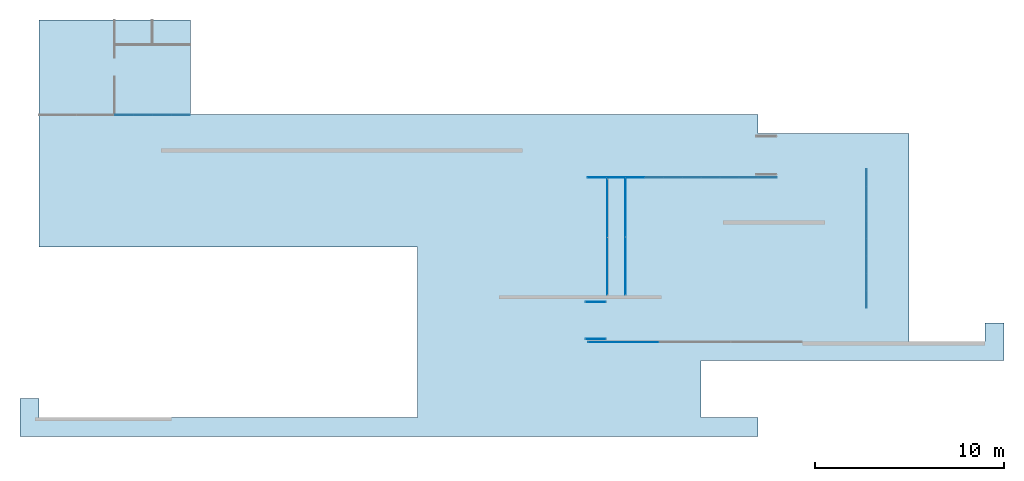
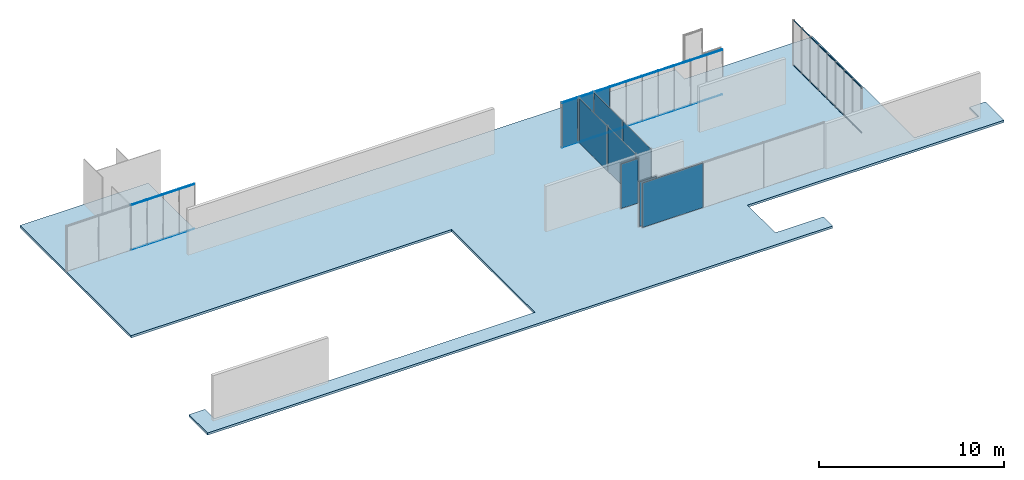
# One storey, part 7 of 8: 44 members, 10 plates, 1 slab, 8 elements without a shape of their own.
"""IFC2X3 building model written with IfcOpenShell, lengths in millimetres."""

from ifc_helpers import new_model, entity, si_unit, converted_unit, direction, frame, frame_2d, origin, origin_2d_with_axis, place, context, subcontext, project, spatial, polyline, rectangle, outline, extrude, source, transform, mapped, material, layer, layer_set, layer_usage, type_object, type_shapes, element, aggregate, save


model = new_model("IFC2X3")

# Units and contexts
model_context = context("Model", 3, precision=1e-06, world=origin(), true_north=direction((2.0, 6.12303176911189e-17, 1.0)))
context_of_model = context(None, 3, precision=1e-06, world=origin(), true_north=direction((2.0, 6.12303176911189e-17, 1.0)))
body_context = subcontext(model_context, "Body", "Model", "MODEL_VIEW")
ifc_project = project(units=[si_unit("LENGTHUNIT", "METRE", prefix="MILLI"), si_unit("AREAUNIT", "SQUARE_METRE", prefix="MILLI"), si_unit("VOLUMEUNIT", "CUBIC_METRE", prefix="MILLI"), converted_unit("PLANEANGLEUNIT", "DEGREE", entity("IfcRatioMeasure", 0.0174532925199433), si_unit("PLANEANGLEUNIT", "RADIAN"), dimensions=[0, 0, 0, 0, 0, 0, 0]), si_unit("TIMEUNIT", "SECOND")], contexts=[model_context, context_of_model])

# Site, building, storey
site_placement = place(None, origin())
site = spatial("IfcSite", under=ifc_project, at=site_placement, CompositionType="ELEMENT")
building_placement = place(site_placement, origin())
building = spatial("IfcBuilding", under=site, at=building_placement, CompositionType="ELEMENT")
storey_placement = place(building_placement, frame((0.0, 0.0, 1500.0)))
storey = spatial("IfcBuildingStorey", under=building, at=storey_placement, Name="Level 1", CompositionType="ELEMENT", Elevation=1500.0)

# Curtain wall, members
curtain_wall_1_placement = place(storey_placement, origin())
curtain_wall_1 = element("IfcCurtainWall", 1, at=curtain_wall_1_placement, inside=storey, Name="Curtain Wall:Curtain Wall", ObjectType="Curtain Wall:Curtain Wall:334")
member_1_placement = place(storey_placement, origin())
member_1 = element("IfcMember", 2, at=member_1_placement, Name="Curtain Wall:Curtain Wall:8490", ObjectType="Curtain Wall:Curtain Wall:8490", context=body_context, shape_type="SweptSolid", body=[
    extrude(rectangle(XDim=971.875, YDim=29.9999999999997, at=frame_2d((1.10844666778576e-12, -5.41788836017076e-13), x_axis=(1.0, 0.0))), frame((-19489.6875, 5875.0, 2970.0), z_axis=(0.0, 0.0, 1.0), x_axis=(-1.0, 0.0, 0.0)), (0.0, 0.0, 1.0), 30.0000000000002),
])
member_2_placement = place(storey_placement, origin())
member_2 = element("IfcMember", 3, at=member_2_placement, Name="Curtain Wall:Curtain Wall:8490", ObjectType="Curtain Wall:Curtain Wall:8490", context=body_context, shape_type="SweptSolid", body=[
    extrude(rectangle(XDim=971.874999999998, YDim=29.9999999999997, at=frame_2d((-2.18847162614111e-12, -5.41788836017076e-13), x_axis=(1.0, 0.0))), frame((-20491.5625, 5875.0, 2970.0), z_axis=(0.0, 0.0, 1.0), x_axis=(-1.0, 0.0, 0.0)), (0.0, 0.0, 1.0), 30.0000000000002),
])
member_3_placement = place(storey_placement, origin())
member_3 = element("IfcMember", 4, at=member_3_placement, Name="Curtain Wall:Curtain Wall:8490", ObjectType="Curtain Wall:Curtain Wall:8490", context=body_context, shape_type="SweptSolid", body=[
    extrude(rectangle(XDim=941.874999999996, YDim=29.9999999999997, at=frame_2d((0.0, -5.41788836017076e-13), x_axis=(1.0, 0.0))), frame((-17500.9375, 5875.0, 0.0)), (0.0, 0.0, 1.0), 29.9999999999999),
])
member_4_placement = place(storey_placement, origin())
member_4 = element("IfcMember", 5, at=member_4_placement, Name="Curtain Wall:Curtain Wall:8490", ObjectType="Curtain Wall:Curtain Wall:8490", context=body_context, shape_type="SweptSolid", body=[
    extrude(rectangle(XDim=971.875, YDim=29.9999999999997, at=frame_2d((-1.10844666778576e-12, -5.41788836017076e-13), x_axis=(1.0, 0.0))), frame((-18487.8125, 5875.0, 0.0)), (0.0, 0.0, 1.0), 29.9999999999999),
])
member_5_placement = place(storey_placement, origin())
member_5 = element("IfcMember", 6, at=member_5_placement, Name="Curtain Wall:Curtain Wall:8490", ObjectType="Curtain Wall:Curtain Wall:8490", context=body_context, shape_type="SweptSolid", body=[
    extrude(rectangle(XDim=971.875, YDim=29.9999999999997, at=frame_2d((-1.10844666778576e-12, 5.41788836017076e-13), x_axis=(1.0, 0.0))), frame((-19489.6875, 5875.0, 0.0)), (0.0, 0.0, 1.0), 29.9999999999999),
])
member_6_placement = place(storey_placement, origin())
member_6 = element("IfcMember", 7, at=member_6_placement, Name="Curtain Wall:Curtain Wall:8490", ObjectType="Curtain Wall:Curtain Wall:8490", context=body_context, shape_type="SweptSolid", body=[
    extrude(rectangle(XDim=971.874999999998, YDim=29.9999999999997, at=frame_2d((2.18847162614111e-12, -5.41788836017076e-13), x_axis=(1.0, 0.0))), frame((-20491.5625, 5875.0, 0.0)), (0.0, 0.0, 1.0), 29.9999999999999),
])
member_7_placement = place(storey_placement, origin())
member_7 = element("IfcMember", 8, at=member_7_placement, Name="Curtain Wall:Curtain Wall:8490", ObjectType="Curtain Wall:Curtain Wall:8490", context=body_context, shape_type="SweptSolid", body=[
    extrude(rectangle(XDim=941.874999999996, YDim=29.9999999999997, at=frame_2d((-2.1600499167107e-12, -5.41788836017076e-13), x_axis=(1.0, 0.0))), frame((-17500.9375, 5875.0, 2970.0), z_axis=(0.0, 0.0, 1.0), x_axis=(-1.0, 0.0, 0.0)), (0.0, 0.0, 1.0), 30.0000000000002),
])
member_8_placement = place(storey_placement, origin())
member_8 = element("IfcMember", 9, at=member_8_placement, Name="Curtain Wall:Curtain Wall:8490", ObjectType="Curtain Wall:Curtain Wall:8490", context=body_context, shape_type="SweptSolid", body=[
    extrude(rectangle(XDim=971.875, YDim=29.9999999999997, at=frame_2d((-1.10844666778576e-12, 5.41788836017076e-13), x_axis=(1.0, 0.0))), frame((-18487.8125, 5875.0, 2970.0), z_axis=(0.0, 0.0, 1.0), x_axis=(-1.0, 0.0, 0.0)), (0.0, 0.0, 1.0), 30.0000000000002),
])
aggregate(curtain_wall_1, [member_1, member_2, member_3, member_4, member_5, member_6, member_7, member_8])

curtain_wall_2_placement = place(storey_placement, origin())
curtain_wall_2 = element("IfcCurtainWall", 10, at=curtain_wall_2_placement, inside=storey, Name="Curtain Wall:Curtain Wall", ObjectType="Curtain Wall:Curtain Wall:334")
member_9_placement = place(storey_placement, origin())
member_9 = element("IfcMember", 11, at=member_9_placement, Name="Curtain Wall:Curtain Wall:8490", ObjectType="Curtain Wall:Curtain Wall:8490", context=body_context, shape_type="SweptSolid", body=[
    extrude(rectangle(XDim=971.5, YDim=30.0000000000002, at=frame_2d((0.0, 2.70894418008538e-13), x_axis=(1.0, 0.0))), frame((5494.75, 2575.0, 2970.0)), (0.0, 0.0, 1.0), 30.0000000000002),
])
member_10_placement = place(storey_placement, origin())
member_10 = element("IfcMember", 12, at=member_10_placement, Name="Curtain Wall:Curtain Wall:8490", ObjectType="Curtain Wall:Curtain Wall:8490", context=body_context, shape_type="SweptSolid", body=[
    extrude(rectangle(XDim=971.5, YDim=30.0000000000002, at=frame_2d((0.0, 2.70894418008538e-13), x_axis=(1.0, 0.0))), frame((6496.25, 2575.0, 2970.0)), (0.0, 0.0, 1.0), 30.0000000000002),
])
member_11_placement = place(storey_placement, origin())
member_11 = element("IfcMember", 13, at=member_11_placement, Name="Curtain Wall:Curtain Wall:8490", ObjectType="Curtain Wall:Curtain Wall:8490", context=body_context, shape_type="SweptSolid", body=[
    extrude(rectangle(XDim=971.5, YDim=30.0000000000002, at=frame_2d((0.0, 2.70894418008538e-13), x_axis=(1.0, 0.0))), frame((7497.75, 2575.0, 2970.0)), (0.0, 0.0, 1.0), 30.0000000000002),
])
member_12_placement = place(storey_placement, origin())
member_12 = element("IfcMember", 14, at=member_12_placement, Name="Curtain Wall:Curtain Wall:8490", ObjectType="Curtain Wall:Curtain Wall:8490", context=body_context, shape_type="SweptSolid", body=[
    extrude(rectangle(XDim=971.5, YDim=30.0000000000002, at=frame_2d((0.0, 2.70894418008538e-13), x_axis=(1.0, 0.0))), frame((8499.25, 2575.0, 2970.0)), (0.0, 0.0, 1.0), 30.0000000000002),
])
member_13_placement = place(storey_placement, origin())
member_13 = element("IfcMember", 15, at=member_13_placement, Name="Curtain Wall:Curtain Wall:8490", ObjectType="Curtain Wall:Curtain Wall:8490", context=body_context, shape_type="SweptSolid", body=[
    extrude(rectangle(XDim=971.5, YDim=30.0000000000002, at=frame_2d((0.0, 2.70894418008538e-13), x_axis=(1.0, 0.0))), frame((9500.75, 2575.0, 2970.0)), (0.0, 0.0, 1.0), 30.0000000000002),
])
member_14_placement = place(storey_placement, origin())
member_14 = element("IfcMember", 16, at=member_14_placement, Name="Curtain Wall:Curtain Wall:8490", ObjectType="Curtain Wall:Curtain Wall:8490", context=body_context, shape_type="SweptSolid", body=[
    extrude(rectangle(XDim=971.5, YDim=30.0000000000002, at=frame_2d((0.0, 2.70894418008538e-13), x_axis=(1.0, 0.0))), frame((10502.25, 2575.0, 2970.0)), (0.0, 0.0, 1.0), 30.0000000000002),
])
member_15_placement = place(storey_placement, origin())
member_15 = element("IfcMember", 17, at=member_15_placement, Name="Curtain Wall:Curtain Wall:8490", ObjectType="Curtain Wall:Curtain Wall:8490", context=body_context, shape_type="SweptSolid", body=[
    extrude(rectangle(XDim=971.5, YDim=30.0000000000002, at=frame_2d((0.0, 2.70894418008538e-13), x_axis=(1.0, 0.0))), frame((11503.75, 2575.0, 2970.0)), (0.0, 0.0, 1.0), 30.0000000000002),
])
member_16_placement = place(storey_placement, origin())
member_16 = element("IfcMember", 18, at=member_16_placement, Name="Curtain Wall:Curtain Wall:8490", ObjectType="Curtain Wall:Curtain Wall:8490", context=body_context, shape_type="SweptSolid", body=[
    extrude(rectangle(XDim=971.5, YDim=30.0000000000002, at=frame_2d((0.0, 2.70894418008538e-13), x_axis=(1.0, 0.0))), frame((12505.25, 2575.0, 2970.0)), (0.0, 0.0, 1.0), 30.0000000000002),
])
member_17_placement = place(storey_placement, origin())
member_17 = element("IfcMember", 19, at=member_17_placement, Name="Curtain Wall:Curtain Wall:8490", ObjectType="Curtain Wall:Curtain Wall:8490", context=body_context, shape_type="SweptSolid", body=[
    extrude(rectangle(XDim=971.5, YDim=30.0000000000002, at=frame_2d((0.0, 2.70894418008538e-13), x_axis=(1.0, 0.0))), frame((13506.75, 2575.0, 2970.0)), (0.0, 0.0, 1.0), 30.0000000000002),
])
member_18_placement = place(storey_placement, origin())
member_18 = element("IfcMember", 20, at=member_18_placement, Name="Curtain Wall:Curtain Wall:8490", ObjectType="Curtain Wall:Curtain Wall:8490", context=body_context, shape_type="SweptSolid", body=[
    extrude(rectangle(XDim=971.500000000003, YDim=30.0000000000002, at=frame_2d((2.8421709430404e-13, 0.0), x_axis=(1.0, 0.0))), frame((4493.25, 2575.0, 0.0), z_axis=(0.0, 0.0, 1.0), x_axis=(-1.0, 0.0, 0.0)), (0.0, 0.0, 1.0), 29.9999999999999),
])
member_19_placement = place(storey_placement, origin())
member_19 = element("IfcMember", 21, at=member_19_placement, Name="Curtain Wall:Curtain Wall:8490", ObjectType="Curtain Wall:Curtain Wall:8490", context=body_context, shape_type="SweptSolid", body=[
    extrude(rectangle(XDim=971.500000000002, YDim=30.0000000000002, at=frame_2d((5.40012479177676e-13, 0.0), x_axis=(1.0, 0.0))), frame((5494.75, 2575.0, 0.0), z_axis=(0.0, 0.0, 1.0), x_axis=(-1.0, 0.0, 0.0)), (0.0, 0.0, 1.0), 29.9999999999999),
])
member_20_placement = place(storey_placement, origin())
member_20 = element("IfcMember", 22, at=member_20_placement, Name="Curtain Wall:Curtain Wall:8490", ObjectType="Curtain Wall:Curtain Wall:8490", context=body_context, shape_type="SweptSolid", body=[
    extrude(rectangle(XDim=971.500000000002, YDim=30.0000000000002, at=frame_2d((5.40012479177676e-13, 0.0), x_axis=(1.0, 0.0))), frame((6496.25, 2575.0, 0.0), z_axis=(0.0, 0.0, 1.0), x_axis=(-1.0, 0.0, 0.0)), (0.0, 0.0, 1.0), 29.9999999999999),
])
member_21_placement = place(storey_placement, origin())
member_21 = element("IfcMember", 23, at=member_21_placement, Name="Curtain Wall:Curtain Wall:8490", ObjectType="Curtain Wall:Curtain Wall:8490", context=body_context, shape_type="SweptSolid", body=[
    extrude(rectangle(XDim=971.500000000002, YDim=30.0000000000002, at=frame_2d((5.40012479177676e-13, 0.0), x_axis=(1.0, 0.0))), frame((7497.75, 2575.0, 0.0), z_axis=(0.0, 0.0, 1.0), x_axis=(-1.0, 0.0, 0.0)), (0.0, 0.0, 1.0), 29.9999999999999),
])
member_22_placement = place(storey_placement, origin())
member_22 = element("IfcMember", 24, at=member_22_placement, Name="Curtain Wall:Curtain Wall:8490", ObjectType="Curtain Wall:Curtain Wall:8490", context=body_context, shape_type="SweptSolid", body=[
    extrude(rectangle(XDim=971.500000000002, YDim=30.0000000000002, at=frame_2d((5.40012479177676e-13, 0.0), x_axis=(1.0, 0.0))), frame((8499.25, 2575.0, 0.0), z_axis=(0.0, 0.0, 1.0), x_axis=(-1.0, 0.0, 0.0)), (0.0, 0.0, 1.0), 29.9999999999999),
])
member_23_placement = place(storey_placement, origin())
member_23 = element("IfcMember", 25, at=member_23_placement, Name="Curtain Wall:Curtain Wall:8490", ObjectType="Curtain Wall:Curtain Wall:8490", context=body_context, shape_type="SweptSolid", body=[
    extrude(rectangle(XDim=971.500000000002, YDim=30.0000000000002, at=frame_2d((-5.40012479177676e-13, 0.0), x_axis=(1.0, 0.0))), frame((9500.75, 2575.0, 0.0), z_axis=(0.0, 0.0, 1.0), x_axis=(-1.0, 0.0, 0.0)), (0.0, 0.0, 1.0), 29.9999999999999),
])
member_24_placement = place(storey_placement, origin())
member_24 = element("IfcMember", 26, at=member_24_placement, Name="Curtain Wall:Curtain Wall:8490", ObjectType="Curtain Wall:Curtain Wall:8490", context=body_context, shape_type="SweptSolid", body=[
    extrude(rectangle(XDim=971.500000000002, YDim=30.0000000000002, at=frame_2d((-1.08002495835535e-12, 0.0), x_axis=(1.0, 0.0))), frame((10502.25, 2575.0, 0.0), z_axis=(0.0, 0.0, 1.0), x_axis=(-1.0, 0.0, 0.0)), (0.0, 0.0, 1.0), 29.9999999999999),
])
member_25_placement = place(storey_placement, origin())
member_25 = element("IfcMember", 27, at=member_25_placement, Name="Curtain Wall:Curtain Wall:8490", ObjectType="Curtain Wall:Curtain Wall:8490", context=body_context, shape_type="SweptSolid", body=[
    extrude(rectangle(XDim=971.500000000002, YDim=30.0000000000002, at=frame_2d((1.08002495835535e-12, 0.0), x_axis=(1.0, 0.0))), frame((11503.75, 2575.0, 0.0), z_axis=(0.0, 0.0, 1.0), x_axis=(-1.0, 0.0, 0.0)), (0.0, 0.0, 1.0), 29.9999999999999),
])
member_26_placement = place(storey_placement, origin())
member_26 = element("IfcMember", 28, at=member_26_placement, Name="Curtain Wall:Curtain Wall:8490", ObjectType="Curtain Wall:Curtain Wall:8490", context=body_context, shape_type="SweptSolid", body=[
    extrude(rectangle(XDim=971.500000000002, YDim=30.0000000000002, at=frame_2d((-1.08002495835535e-12, 0.0), x_axis=(1.0, 0.0))), frame((12505.25, 2575.0, 0.0), z_axis=(0.0, 0.0, 1.0), x_axis=(-1.0, 0.0, 0.0)), (0.0, 0.0, 1.0), 29.9999999999999),
])
member_27_placement = place(storey_placement, origin())
member_27 = element("IfcMember", 29, at=member_27_placement, Name="Curtain Wall:Curtain Wall:8490", ObjectType="Curtain Wall:Curtain Wall:8490", context=body_context, shape_type="SweptSolid", body=[
    extrude(rectangle(XDim=971.500000000002, YDim=30.0000000000002, at=frame_2d((-1.08002495835535e-12, 0.0), x_axis=(1.0, 0.0))), frame((13506.75, 2575.0, 0.0), z_axis=(0.0, 0.0, 1.0), x_axis=(-1.0, 0.0, 0.0)), (0.0, 0.0, 1.0), 29.9999999999999),
])
member_28_placement = place(storey_placement, origin())
member_28 = element("IfcMember", 30, at=member_28_placement, Name="Curtain Wall:Curtain Wall:8490", ObjectType="Curtain Wall:Curtain Wall:8490", context=body_context, shape_type="SweptSolid", body=[
    extrude(rectangle(XDim=971.5, YDim=30.0000000000002, at=frame_2d((0.0, 2.70894418008538e-13), x_axis=(1.0, 0.0))), frame((4493.25, 2575.0, 2970.0)), (0.0, 0.0, 1.0), 30.0000000000002),
])

curtain_wall_3_placement = place(storey_placement, origin())
curtain_wall_3 = element("IfcCurtainWall", 31, at=curtain_wall_3_placement, inside=storey, Name="Curtain Wall:Curtain Wall", ObjectType="Curtain Wall:Curtain Wall:334")
member_29_placement = place(storey_placement, origin())
member_29 = element("IfcMember", 32, at=member_29_placement, Name="Curtain Wall:Curtain Wall:8490", ObjectType="Curtain Wall:Curtain Wall:8490", context=body_context, shape_type="SweptSolid", body=[
    extrude(rectangle(XDim=888.750000000001, YDim=29.9999999999997, at=frame_2d((-2.55795384873636e-13, 1.08268949361445e-12), x_axis=(1.0, 0.0))), frame((18734.4440927411, -2946.875, 2970.0), z_axis=(0.0, 0.0, 1.0), x_axis=(0.0, 1.0, 0.0)), (0.0, 0.0, 1.0), 30.0000000000002),
])
member_30_placement = place(storey_placement, origin())
member_30 = element("IfcMember", 33, at=member_30_placement, Name="Curtain Wall:Curtain Wall:8490", ObjectType="Curtain Wall:Curtain Wall:8490", context=body_context, shape_type="SweptSolid", body=[
    extrude(rectangle(XDim=888.750000000002, YDim=29.9999999999997, at=frame_2d((-1.13686837721616e-13, 0.0), x_axis=(1.0, 0.0))), frame((18734.4440927411, -2028.125, 2970.0), z_axis=(0.0, 0.0, 1.0), x_axis=(0.0, 1.0, 0.0)), (0.0, 0.0, 1.0), 30.0000000000002),
])
member_31_placement = place(storey_placement, origin())
member_31 = element("IfcMember", 34, at=member_31_placement, Name="Curtain Wall:Curtain Wall:8490", ObjectType="Curtain Wall:Curtain Wall:8490", context=body_context, shape_type="SweptSolid", body=[
    extrude(rectangle(XDim=888.750000000001, YDim=29.9999999999997, at=frame_2d((1.13686837721616e-13, 1.08268949361445e-12), x_axis=(1.0, 0.0))), frame((18734.4440927411, -1109.375, 2970.0), z_axis=(0.0, 0.0, 1.0), x_axis=(0.0, 1.0, 0.0)), (0.0, 0.0, 1.0), 30.0000000000002),
])
member_32_placement = place(storey_placement, origin())
member_32 = element("IfcMember", 35, at=member_32_placement, Name="Curtain Wall:Curtain Wall:8490", ObjectType="Curtain Wall:Curtain Wall:8490", context=body_context, shape_type="SweptSolid", body=[
    extrude(rectangle(XDim=888.750000000001, YDim=29.9999999999997, at=origin_2d_with_axis()), frame((18734.4440927411, -190.624999999999, 2970.0), z_axis=(0.0, 0.0, 1.0), x_axis=(0.0, 1.0, 0.0)), (0.0, 0.0, 1.0), 30.0000000000002),
])
member_33_placement = place(storey_placement, origin())
member_33 = element("IfcMember", 36, at=member_33_placement, Name="Curtain Wall:Curtain Wall:8490", ObjectType="Curtain Wall:Curtain Wall:8490", context=body_context, shape_type="SweptSolid", body=[
    extrude(rectangle(XDim=888.750000000001, YDim=29.9999999999997, at=frame_2d((-5.6843418860808e-14, 0.0), x_axis=(1.0, 0.0))), frame((18734.4440927411, 728.125000000001, 2970.0), z_axis=(0.0, 0.0, 1.0), x_axis=(0.0, 1.0, 0.0)), (0.0, 0.0, 1.0), 30.0000000000002),
])
member_34_placement = place(storey_placement, origin())
member_34 = element("IfcMember", 37, at=member_34_placement, Name="Curtain Wall:Curtain Wall:8490", ObjectType="Curtain Wall:Curtain Wall:8490", context=body_context, shape_type="SweptSolid", body=[
    extrude(rectangle(XDim=888.750000000001, YDim=29.9999999999997, at=frame_2d((1.13686837721616e-13, -1.08268949361445e-12), x_axis=(1.0, 0.0))), frame((18734.4440927411, 1646.875, 2970.0), z_axis=(0.0, 0.0, 1.0), x_axis=(0.0, 1.0, 0.0)), (0.0, 0.0, 1.0), 30.0000000000002),
])
member_35_placement = place(storey_placement, origin())
member_35 = element("IfcMember", 38, at=member_35_placement, Name="Curtain Wall:Curtain Wall:8490", ObjectType="Curtain Wall:Curtain Wall:8490", context=body_context, shape_type="SweptSolid", body=[
    extrude(rectangle(XDim=888.750000000001, YDim=29.9999999999997, at=origin_2d_with_axis()), frame((18734.4440927411, 2565.625, 2970.0), z_axis=(0.0, 0.0, 1.0), x_axis=(0.0, 1.0, 0.0)), (0.0, 0.0, 1.0), 30.0000000000002),
])
member_36_placement = place(storey_placement, origin())
member_36 = element("IfcMember", 39, at=member_36_placement, Name="Curtain Wall:Curtain Wall:8490", ObjectType="Curtain Wall:Curtain Wall:8490", context=body_context, shape_type="SweptSolid", body=[
    extrude(rectangle(XDim=888.75, YDim=29.9999999999997, at=frame_2d((2.8421709430404e-13, 1.08268949361445e-12), x_axis=(1.0, 0.0))), frame((18734.4440927411, -3865.625, 0.0), z_axis=(0.0, 0.0, 1.0), x_axis=(0.0, -1.0, 0.0)), (0.0, 0.0, 1.0), 29.9999999999999),
])
member_37_placement = place(storey_placement, origin())
member_37 = element("IfcMember", 40, at=member_37_placement, Name="Curtain Wall:Curtain Wall:8490", ObjectType="Curtain Wall:Curtain Wall:8490", context=body_context, shape_type="SweptSolid", body=[
    extrude(rectangle(XDim=888.75, YDim=29.9999999999997, at=frame_2d((-2.8421709430404e-13, 2.16537898722891e-12), x_axis=(1.0, 0.0))), frame((18734.4440927411, -2946.875, 0.0), z_axis=(0.0, 0.0, 1.0), x_axis=(0.0, -1.0, 0.0)), (0.0, 0.0, 1.0), 29.9999999999999),
])
member_38_placement = place(storey_placement, origin())
member_38 = element("IfcMember", 41, at=member_38_placement, Name="Curtain Wall:Curtain Wall:8490", ObjectType="Curtain Wall:Curtain Wall:8490", context=body_context, shape_type="SweptSolid", body=[
    extrude(rectangle(XDim=888.75, YDim=29.9999999999997, at=frame_2d((0.0, 1.08268949361445e-12), x_axis=(1.0, 0.0))), frame((18734.4440927411, -2028.125, 0.0), z_axis=(0.0, 0.0, 1.0), x_axis=(0.0, -1.0, 0.0)), (0.0, 0.0, 1.0), 29.9999999999999),
])
member_39_placement = place(storey_placement, origin())
member_39 = element("IfcMember", 42, at=member_39_placement, Name="Curtain Wall:Curtain Wall:8490", ObjectType="Curtain Wall:Curtain Wall:8490", context=body_context, shape_type="SweptSolid", body=[
    extrude(rectangle(XDim=888.75, YDim=29.9999999999997, at=frame_2d((-1.4210854715202e-13, 2.16537898722891e-12), x_axis=(1.0, 0.0))), frame((18734.4440927411, -1109.375, 0.0), z_axis=(0.0, 0.0, 1.0), x_axis=(0.0, -1.0, 0.0)), (0.0, 0.0, 1.0), 29.9999999999999),
])
member_40_placement = place(storey_placement, origin())
member_40 = element("IfcMember", 43, at=member_40_placement, Name="Curtain Wall:Curtain Wall:8490", ObjectType="Curtain Wall:Curtain Wall:8490", context=body_context, shape_type="SweptSolid", body=[
    extrude(rectangle(XDim=888.75, YDim=29.9999999999997, at=frame_2d((0.0, -1.08268949361445e-12), x_axis=(1.0, 0.0))), frame((18734.4440927411, -190.625, 0.0), z_axis=(0.0, 0.0, 1.0), x_axis=(0.0, -1.0, 0.0)), (0.0, 0.0, 1.0), 29.9999999999999),
])
member_41_placement = place(storey_placement, origin())
member_41 = element("IfcMember", 44, at=member_41_placement, Name="Curtain Wall:Curtain Wall:8490", ObjectType="Curtain Wall:Curtain Wall:8490", context=body_context, shape_type="SweptSolid", body=[
    extrude(rectangle(XDim=888.75, YDim=29.9999999999997, at=frame_2d((-5.6843418860808e-14, 1.08268949361445e-12), x_axis=(1.0, 0.0))), frame((18734.4440927411, 728.125000000001, 0.0), z_axis=(0.0, 0.0, 1.0), x_axis=(0.0, -1.0, 0.0)), (0.0, 0.0, 1.0), 29.9999999999999),
])
member_42_placement = place(storey_placement, origin())
member_42 = element("IfcMember", 45, at=member_42_placement, Name="Curtain Wall:Curtain Wall:8490", ObjectType="Curtain Wall:Curtain Wall:8490", context=body_context, shape_type="SweptSolid", body=[
    extrude(rectangle(XDim=888.75, YDim=29.9999999999997, at=frame_2d((8.5265128291212e-14, 0.0), x_axis=(1.0, 0.0))), frame((18734.4440927411, 1646.875, 0.0), z_axis=(0.0, 0.0, 1.0), x_axis=(0.0, -1.0, 0.0)), (0.0, 0.0, 1.0), 29.9999999999999),
])
member_43_placement = place(storey_placement, origin())
member_43 = element("IfcMember", 46, at=member_43_placement, Name="Curtain Wall:Curtain Wall:8490", ObjectType="Curtain Wall:Curtain Wall:8490", context=body_context, shape_type="SweptSolid", body=[
    extrude(rectangle(XDim=888.75, YDim=29.9999999999997, at=frame_2d((-2.8421709430404e-13, 1.08268949361445e-12), x_axis=(1.0, 0.0))), frame((18734.4440927411, 2565.625, 0.0), z_axis=(0.0, 0.0, 1.0), x_axis=(0.0, -1.0, 0.0)), (0.0, 0.0, 1.0), 29.9999999999999),
])
member_44_placement = place(storey_placement, origin())
member_44 = element("IfcMember", 47, at=member_44_placement, Name="Curtain Wall:Curtain Wall:8490", ObjectType="Curtain Wall:Curtain Wall:8490", context=body_context, shape_type="SweptSolid", body=[
    extrude(rectangle(XDim=888.750000000002, YDim=29.9999999999997, at=frame_2d((0.0, -2.16537898722891e-12), x_axis=(1.0, 0.0))), frame((18734.444092741, -3865.625, 2970.0), z_axis=(0.0, 0.0, 1.0), x_axis=(0.0, 1.0, 0.0)), (0.0, 0.0, 1.0), 30.0000000000002),
])
aggregate(curtain_wall_3, [member_29, member_30, member_31, member_32, member_33, member_34, member_35, member_36, member_37, member_38, member_39, member_40, member_41, member_42, member_43, member_44])

# Plate
ifc_material_1 = material(Name="Glass")
plate_type_1 = type_object("IfcPlateType", Name="Glazed", PredefinedType="CURTAIN_PANEL")
shared_shape_1 = source(origin(), body_context, "Body", "SweptSolid", [
    extrude(rectangle(XDim=10.0, YDim=971.5, at=origin_2d_with_axis()), frame((0.0, 0.0, 0.0), z_axis=(0.0, 0.0, 1.0), x_axis=(0.0, 1.0, 0.0)), (0.0, 0.0, 1.0), 2940.0),
])
type_shapes(plate_type_1, [shared_shape_1])
plate_1_placement = place(storey_placement, frame((6496.25, 2575.0, 30.0), z_axis=(0.0, 0.0, 1.0), x_axis=(-1.0, 0.0, 0.0)))
plate_1 = element("IfcPlate", 48, at=plate_1_placement, type_object=plate_type_1, material=ifc_material_1, Name="Curtain Wall:Curtain Wall", ObjectType="Glazed", context=body_context, shape_type="MappedRepresentation", body=[
    mapped(shared_shape_1, transform((0.0, 0.0, 0.0), scale=1.0)),
])

plate_2_placement = place(storey_placement, frame((5494.75, 2575.0, 30.0), z_axis=(0.0, 0.0, 1.0), x_axis=(-1.0, 0.0, 0.0)))
plate_2 = element("IfcPlate", 49, at=plate_2_placement, type_object=plate_type_1, material=ifc_material_1, Name="Curtain Wall:Curtain Wall", ObjectType="Glazed", context=body_context, shape_type="MappedRepresentation", body=[
    mapped(shared_shape_1, transform((0.0, 0.0, 0.0), scale=1.0)),
])

plate_3_placement = place(storey_placement, frame((4493.25, 2575.0, 30.0), z_axis=(0.0, 0.0, 1.0), x_axis=(-1.0, 0.0, 0.0)))
plate_3 = element("IfcPlate", 50, at=plate_3_placement, type_object=plate_type_1, material=ifc_material_1, Name="Curtain Wall:Curtain Wall", ObjectType="Glazed", context=body_context, shape_type="MappedRepresentation", body=[
    mapped(shared_shape_1, transform((0.0, 0.0, 0.0), scale=1.0)),
])

aggregate(curtain_wall_2, [plate_1, plate_2, plate_3, member_9, member_10, member_11, member_12, member_13, member_14, member_15, member_16, member_17, member_18, member_19, member_20, member_21, member_22, member_23, member_24, member_25, member_26, member_27, member_28])

# Curtain wall, plates
curtain_wall_4_placement = place(storey_placement, origin())
curtain_wall_4 = element("IfcCurtainWall", 51, at=curtain_wall_4_placement, inside=storey, Name="Curtain Wall:Curtain Wall", ObjectType="Curtain Wall:Curtain Wall:334")
plate_type_2 = type_object("IfcPlateType", Name="Glazed", PredefinedType="CURTAIN_PANEL")
shared_shape_2 = source(origin(), body_context, "Body", "SweptSolid", [
    extrude(rectangle(XDim=10.0, YDim=3075.00000000002, at=origin_2d_with_axis()), frame((0.0, 0.0, 0.0), z_axis=(0.0, 0.0, 1.0), x_axis=(0.0, 1.0, 0.0)), (0.0, 0.0, 1.0), 2940.0),
])
type_shapes(plate_type_2, [shared_shape_2])
plate_4_placement = place(storey_placement, frame((5999.85915853028, 992.500000000011, 30.0), z_axis=(0.0, 0.0, 1.0), x_axis=(0.0, -1.0, 0.0)))
plate_4 = element("IfcPlate", 52, at=plate_4_placement, type_object=plate_type_2, material=ifc_material_1, Name="Curtain Wall:Curtain Wall", ObjectType="Glazed", context=body_context, shape_type="MappedRepresentation", body=[
    mapped(shared_shape_2, transform((0.0, 0.0, 0.0), scale=1.0)),
])
plate_type_3 = type_object("IfcPlateType", Name="Glazed", PredefinedType="CURTAIN_PANEL")
shared_shape_3 = source(origin(), body_context, "Body", "SweptSolid", [
    extrude(rectangle(XDim=10.0, YDim=3045.00000000002, at=origin_2d_with_axis()), frame((0.0, 0.0, 0.0), z_axis=(0.0, 0.0, 1.0), x_axis=(0.0, 1.0, 0.0)), (0.0, 0.0, 1.0), 2940.0),
])
type_shapes(plate_type_3, [shared_shape_3])
plate_5_placement = place(storey_placement, frame((5999.85915853027, -2097.50000000001, 30.0), z_axis=(0.0, 0.0, 1.0), x_axis=(0.0, -1.0, 0.0)))
plate_5 = element("IfcPlate", 53, at=plate_5_placement, type_object=plate_type_3, material=ifc_material_1, Name="Curtain Wall:Curtain Wall", ObjectType="Glazed", context=body_context, shape_type="MappedRepresentation", body=[
    mapped(shared_shape_3, transform((0.0, 0.0, 0.0), scale=1.0)),
])
aggregate(curtain_wall_4, [plate_4, plate_5])

curtain_wall_5_placement = place(storey_placement, origin())
curtain_wall_5 = element("IfcCurtainWall", 54, at=curtain_wall_5_placement, inside=storey, Name="Curtain Wall:Curtain Wall", ObjectType="Curtain Wall:Curtain Wall:334")
plate_type_4 = type_object("IfcPlateType", Name="Glazed", PredefinedType="CURTAIN_PANEL")
shared_shape_4 = source(origin(), body_context, "Body", "SweptSolid", [
    extrude(rectangle(XDim=10.0, YDim=3050.0, at=origin_2d_with_axis()), frame((0.0, 0.0, 0.0), z_axis=(0.0, 0.0, 1.0), x_axis=(0.0, 1.0, 0.0)), (0.0, 0.0, 1.0), 2940.0),
])
type_shapes(plate_type_4, [shared_shape_4])
plate_6_placement = place(storey_placement, frame((5037.5, 955.0, 30.0), z_axis=(0.0, 0.0, 1.0), x_axis=(0.0, -1.0, 0.0)))
plate_6 = element("IfcPlate", 55, at=plate_6_placement, type_object=plate_type_4, material=ifc_material_1, Name="Curtain Wall:Curtain Wall", ObjectType="Glazed", context=body_context, shape_type="MappedRepresentation", body=[
    mapped(shared_shape_4, transform((0.0, 0.0, 0.0), scale=1.0)),
])
plate_type_5 = type_object("IfcPlateType", Name="Glazed", PredefinedType="CURTAIN_PANEL")
shared_shape_5 = source(origin(), body_context, "Body", "SweptSolid", [
    extrude(rectangle(XDim=10.0, YDim=3020.0, at=origin_2d_with_axis()), frame((0.0, 0.0, 0.0), z_axis=(0.0, 0.0, 1.0), x_axis=(0.0, 1.0, 0.0)), (0.0, 0.0, 1.0), 2940.0),
])
type_shapes(plate_type_5, [shared_shape_5])
plate_7_placement = place(storey_placement, frame((5037.49999999999, -2110.0, 30.0), z_axis=(0.0, 0.0, 1.0), x_axis=(0.0, -1.0, 0.0)))
plate_7 = element("IfcPlate", 56, at=plate_7_placement, type_object=plate_type_5, material=ifc_material_1, Name="Curtain Wall:Curtain Wall", ObjectType="Glazed", context=body_context, shape_type="MappedRepresentation", body=[
    mapped(shared_shape_5, transform((0.0, 0.0, 0.0), scale=1.0)),
])
aggregate(curtain_wall_5, [plate_6, plate_7])

# Curtain wall, plate
curtain_wall_6_placement = place(storey_placement, origin())
curtain_wall_6 = element("IfcCurtainWall", 57, at=curtain_wall_6_placement, inside=storey, Name="Curtain Wall:Curtain Wall", ObjectType="Curtain Wall:Curtain Wall:334")
plate_type_6 = type_object("IfcPlateType", Name="Glazed", PredefinedType="CURTAIN_PANEL")
shared_shape_6 = source(origin(), body_context, "Body", "SweptSolid", [
    extrude(rectangle(XDim=10.0, YDim=3746.66666666667, at=origin_2d_with_axis()), frame((0.0, 0.0, 0.0), z_axis=(0.0, 0.0, 1.0), x_axis=(0.0, 1.0, 0.0)), (0.0, 0.0, 1.0), 2940.0),
])
type_shapes(plate_type_6, [shared_shape_6])
plate_8_placement = place(storey_placement, frame((5893.33333333333, -6125.0, 30.0), z_axis=(0.0, 0.0, 1.0), x_axis=(-1.0, 0.0, 0.0)))
plate_8 = element("IfcPlate", 58, at=plate_8_placement, type_object=plate_type_6, material=ifc_material_1, Name="Curtain Wall:Curtain Wall", ObjectType="Glazed", context=body_context, shape_type="MappedRepresentation", body=[
    mapped(shared_shape_6, transform((0.0, 0.0, 0.0), scale=1.0)),
])
aggregate(curtain_wall_6, [plate_8])

curtain_wall_7_placement = place(storey_placement, origin())
curtain_wall_7 = element("IfcCurtainWall", 59, at=curtain_wall_7_placement, inside=storey, Name="Curtain Wall:Curtain Wall Zero Grid lines", ObjectType="Curtain Wall:Curtain Wall Zero Grid lines")
plate_type_7 = type_object("IfcPlateType", Name="Glazed", PredefinedType="CURTAIN_PANEL")
shared_shape_7 = source(origin(), body_context, "Body", "SweptSolid", [
    extrude(rectangle(XDim=10.0, YDim=1060.0, at=origin_2d_with_axis()), frame((0.0, 0.0, 0.0), z_axis=(0.0, 0.0, 1.0), x_axis=(0.0, 1.0, 0.0)), (0.0, 0.0, 1.0), 2940.0),
])
type_shapes(plate_type_7, [shared_shape_7])
plate_9_placement = place(storey_placement, frame((4435.0, -4000.0, 30.0)))
plate_9 = element("IfcPlate", 60, at=plate_9_placement, type_object=plate_type_7, material=ifc_material_1, Name="Curtain Wall:Curtain Wall Zero Grid lines", ObjectType="Glazed", context=body_context, shape_type="MappedRepresentation", body=[
    mapped(shared_shape_7, transform((0.0, 0.0, 0.0), scale=1.0)),
])
aggregate(curtain_wall_7, [plate_9])

curtain_wall_8_placement = place(storey_placement, origin())
curtain_wall_8 = element("IfcCurtainWall", 61, at=curtain_wall_8_placement, inside=storey, Name="Curtain Wall:Curtain Wall Zero Grid lines", ObjectType="Curtain Wall:Curtain Wall Zero Grid lines")
plate_10_placement = place(storey_placement, frame((4435.0, -5960.0, 30.0)))
plate_10 = element("IfcPlate", 62, at=plate_10_placement, type_object=plate_type_7, material=ifc_material_1, Name="Curtain Wall:Curtain Wall Zero Grid lines", ObjectType="Glazed", context=body_context, shape_type="MappedRepresentation", body=[
    mapped(shared_shape_7, transform((0.0, 0.0, 0.0), scale=1.0)),
])
aggregate(curtain_wall_8, [plate_10])

# Slab
ifc_material_2 = material(Name="Default Floor")
ifc_layer = layer(ifc_material_2, 150.0)
ifc_layer_set = layer_set([ifc_layer], Name="Floor:Generic 150mm")
ifc_layer_usage = layer_usage(ifc_layer_set, "AXIS3", "POSITIVE", 0.0)
slab_placement = place(storey_placement, frame((-26000.0, -11100.0, -150.0)))
element("IfcSlab", 63, at=slab_placement, inside=storey, material=ifc_layer_usage, Name="Floor:Generic 150mm", ObjectType="Floor:Generic 150mm", PredefinedType="FLOOR", context=body_context, shape_type="SweptSolid", body=[
    extrude(outline(polyline([(26000.0, -9000.0), (25000.0, -9000.0), (25000.0, -10000.0), (5000.0, -10000.0), (5000.0, -1000.0), (25000.0, -1000.0), (25000.0, 11000.0), (17000.0, 11000.0), (17000.0, 6000.0), (-13000.0, 6000.0), (-13000.0, 5000.0), (-20990.0, 5000.0), (-20990.0, -6000.0), (-25000.0, -6000.0), (-25000.0, -5000.0), (-26000.0, -5000.0), (-26000.0, -7000.0), (-10000.0, -7000.0), (-10000.0, -10000.0), (-13000.0, -10000.0), (-13000.0, -11000.0), (26000.0, -11000.0), (26000.0, -9000.0)])), frame((26000.0, 11000.0, 150.0), z_axis=(0.0, 0.0, -1.0), x_axis=(-1.0, 0.0, 0.0)), (0.0, 0.0, 1.0), 150.0),
])

save(model, "model.ifc")
